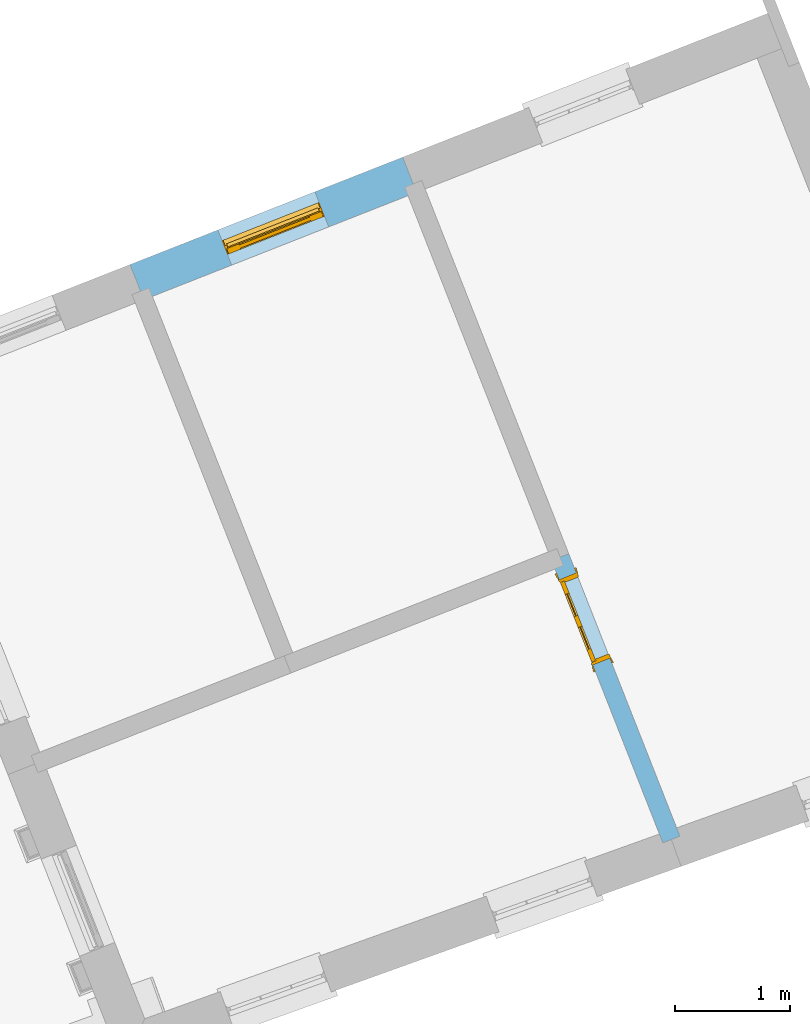
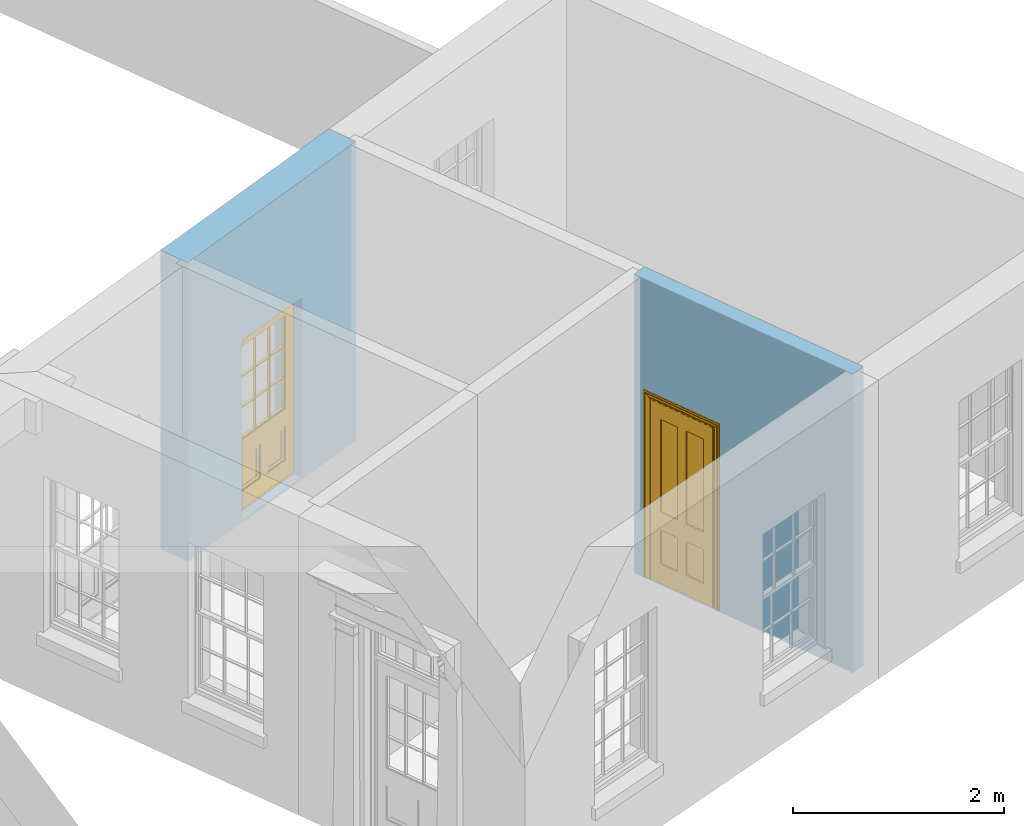
# One storey, part 6 of 8: 2 doors, 2 openings, plus 2 elements that do not belong to this part.
"""IFC2X3 building model written with IfcOpenShell, lengths in metres."""

from ifc_helpers import new_model, si_unit, frame, origin, place, context, subcontext, project, spatial, polyline, outline, extrude, faceted_brep, material, layer, layer_set, layer_usage, element, fill, save


model = new_model("IFC2X3")

# Units and contexts
model_context = context("Model", 3, world=origin())
body_context = subcontext(model_context, "Body", "Model", "MODEL_VIEW")
ifc_project = project(units=[si_unit("PLANEANGLEUNIT", "RADIAN"), si_unit("MASSUNIT", "GRAM", prefix="KILO"), si_unit("FORCEUNIT", "NEWTON", prefix="KILO"), si_unit("LENGTHUNIT", "METRE")], contexts=[model_context])

# Site, building, storey
site_placement = place(None, origin())
site = spatial("IfcSite", under=ifc_project, at=site_placement, CompositionType="ELEMENT")
building_placement = place(None, origin())
building = spatial("IfcBuilding", under=site, at=building_placement, Name="Building plot-4", CompositionType="ELEMENT")
storey_placement = place(None, frame((0.0, 0.0, 3.0)))
storey = spatial("IfcBuildingStorey", under=building, at=storey_placement, Name="Floor 0", CompositionType="ELEMENT", Elevation=3.0)

# Wall, opening, door
ifc_material_1 = material(Name="Masonry")
ifc_layer_1 = layer(ifc_material_1, 0.33, ventilated=False)
ifc_layer_set_1 = layer_set([ifc_layer_1], Name="My Wall")
ifc_layer_usage_1 = layer_usage(ifc_layer_set_1, "AXIS2", "NEGATIVE", 0.08)
wall_1_placement = place(storey_placement, origin())
wall_1 = element("IfcWallStandardCase", 1, at=wall_1_placement, inside=storey, material=ifc_layer_usage_1, Name="exterior", context=body_context, shape_type="SweptSolid", body=[
    extrude(outline(polyline([(52.0366920680449, 53.7732303747513), (51.9157706887258, 54.0802776349957), (49.5373999145512, 53.1436274453256), (49.6583212938703, 52.8365801850812), (52.0366920680449, 53.7732303747513)])), origin(), (0.0, 0.0, 1.0), 3.45),
])
opening_1_placement = place(storey_placement, frame((0.0, 0.0, 0.02)))
opening_1 = element("IfcOpeningElement", 2, at=opening_1_placement, cuts=wall_1, Name="Opening", ObjectType="Opening", context=body_context, shape_type="SweptSolid", body=[
    extrude(outline(polyline([(51.1499383422784, 53.7786774722522), (50.3032322609986, 53.4452276080691), (50.4241536403177, 53.1381803478247), (51.2708597215976, 53.4716302120078), (51.1499383422784, 53.7786774722522)])), origin(), (0.0, 0.0, 1.0), 2.08),
])
door_1_placement = place(storey_placement, frame((51.2415454478232, 53.546065911461, 0.02), z_axis=(0.0, 0.0, 1.0), x_axis=(-0.846706081279841, -0.333449864183102, 0.0)))
door_1 = element("IfcDoor", 3, at=door_1_placement, inside=storey, Name="bedroom door", OverallHeight=2.08, OverallWidth=0.91, context=body_context, shape_type="Brep", held_by="IfcProductRepresentation", body=[
    faceted_brep([(0.545, -0.055, 0.265), (0.745, -0.055, 0.265), (0.745, -0.05, 0.265), (0.545, -0.05, 0.265), (0.745, -0.05, 0.58), (0.545, -0.05, 0.58), (0.545, -0.055, 0.58), (0.515, -0.06, 0.235), (0.775, -0.06, 0.235), (0.745, -0.055, 0.58), (0.515, -0.06, 0.61), (0.515, -0.065, 0.235), (0.775, -0.065, 0.235), (0.775, -0.06, 0.61), (0.515, -0.065, 0.61), (0.785, -0.065, 0.225), (0.505, -0.065, 0.225), (0.775, -0.065, 0.61), (0.505, -0.065, 0.62), (0.785, -0.065, 0.62), (0.505, -0.07, 0.225), (0.785, -0.07, 0.225), (0.505, -0.07, 0.62), (0.785, -0.07, 0.62), (0.883, -0.07, 0.075), (0.898, -0.07, 0.075), (0.405, -0.07, 0.62), (0.405, -0.07, 0.225), (0.027, -0.07, 0.075), (0.785, -0.07, 0.82), (0.125, -0.07, 0.82), (0.405, -0.065, 0.62), (0.405, -0.065, 0.225), (0.898, -0.07, 2.068), (0.027, -0.08, 0.075), (0.883, -0.08, 0.075), (0.125, -0.07, 0.225), (0.012, -0.07, 0.075), (0.785, -0.06, 0.82), (0.125, -0.06, 0.82), (0.125, -0.07, 0.62), (0.125, -0.065, 0.62), (0.395, -0.065, 0.61), (0.395, -0.065, 0.235), (0.125, -0.065, 0.225), (0.785, -0.07, 1.895), (0.027, -0.11, 0.045), (0.883, -0.11, 0.045), (0.558333, -0.06, 0.83), (0.351667, -0.06, 0.83), (0.125, -0.07, 1.895), (0.125, -0.06, 1.895), (0.785, -0.06, 1.895), (0.012, -0.07, 2.068), (0.135, -0.065, 0.61), (0.395, -0.06, 0.61), (0.395, -0.06, 0.235), (0.135, -0.065, 0.235), (0.027, -0.11, 0.027), (0.883, -0.11, 0.027), (0.568333, -0.06, 0.83), (0.558333, -0.03, 0.83), (0.351667, -0.03, 0.83), (0.341667, -0.06, 0.83), (0.135, -0.06, 1.185), (0.135, -0.06, 1.53), (0.775, -0.06, 1.53), (0.775, -0.06, 1.185), (0.135, -0.06, 0.61), (0.365, -0.055, 0.58), (0.365, -0.055, 0.265), (0.135, -0.06, 0.235), (0.568333, -0.06, 1.175), (0.558333, -0.06, 1.175), (0.775, -0.06, 0.83), (0.558333, -0.03, 1.175), (0.785, -0.03, 0.82), (0.125, -0.03, 0.82), (0.351667, -0.03, 1.175), (0.351667, -0.06, 1.175), (0.341667, -0.06, 1.175), (0.135, -0.06, 0.83), (0.135, -0.06, 1.175), (0.135, -0.03, 1.185), (0.135, -0.03, 1.53), (0.135, -0.06, 1.54), (0.351667, -0.06, 1.885), (0.558333, -0.06, 1.885), (0.775, -0.03, 1.53), (0.775, -0.03, 1.185), (0.775, -0.06, 1.175), (0.775, -0.06, 1.54), (0.165, -0.055, 0.58), (0.365, -0.05, 0.58), (0.365, -0.05, 0.265), (0.165, -0.055, 0.265), (0.568333, -0.03, 0.83), (0.568333, -0.03, 1.175), (0.568333, -0.06, 1.185), (0.558333, -0.06, 1.185), (0.775, -0.03, 0.83), (0.785, -0.02, 0.82), (0.125, -0.02, 0.82), (0.341667, -0.03, 0.83), (0.341667, -0.03, 1.175), (0.351667, -0.06, 1.185), (0.341667, -0.06, 1.185), (0.135, -0.03, 0.83), (0.341667, -0.03, 1.185), (0.125, -0.03, 1.895), (0.341667, -0.03, 1.53), (0.341667, -0.06, 1.53), (0.135, -0.06, 1.885), (0.341667, -0.06, 1.54), (0.341667, -0.06, 1.885), (0.558333, -0.03, 1.885), (0.351667, -0.03, 1.885), (0.568333, -0.06, 1.885), (0.785, -0.03, 1.895), (0.568333, -0.03, 1.185), (0.568333, -0.06, 1.53), (0.568333, -0.03, 1.53), (0.568333, -0.06, 1.54), (0.775, -0.06, 1.885), (0.165, -0.05, 0.58), (0.165, -0.05, 0.265), (0.775, -0.03, 1.175), (0.558333, -0.06, 1.53), (0.351667, -0.03, 1.185), (0.558333, -0.03, 1.185), (0.505, -0.02, 0.62), (0.405, -0.02, 0.62), (0.125, -0.02, 1.895), (0.785, -0.02, 1.895), (0.351667, -0.06, 1.53), (0.135, -0.03, 1.175), (0.135, -0.03, 1.54), (0.341667, -0.03, 1.54), (0.135, -0.03, 1.885), (0.351667, -0.06, 1.54), (0.558333, -0.03, 1.54), (0.558333, -0.06, 1.54), (0.351667, -0.03, 1.54), (0.775, -0.03, 1.54), (0.568333, -0.03, 1.54), (0.775, -0.03, 1.885), (0.558333, -0.03, 1.53), (0.405, -0.02, 0.225), (0.505, -0.02, 0.225), (0.125, -0.02, 0.62), (0.785, -0.02, 0.62), (0.012, -0.02, 2.068), (0.898, -0.02, 2.068), (0.351667, -0.03, 1.53), (0.341667, -0.03, 1.885), (0.568333, -0.03, 1.885), (0.405, -0.025, 0.225), (0.405, -0.025, 0.62), (0.505, -0.025, 0.62), (0.505, -0.025, 0.225), (0.898, -0.02, 0.027), (0.012, -0.02, 0.027), (0.125, -0.025, 0.62), (0.785, -0.025, 0.62), (0.395, -0.025, 0.235), (0.395, -0.025, 0.61), (0.125, -0.02, 0.225), (0.125, -0.025, 0.225), (0.515, -0.025, 0.61), (0.515, -0.025, 0.235), (0.785, -0.02, 0.225), (0.785, -0.025, 0.225), (0.135, -0.025, 0.61), (0.775, -0.025, 0.61), (0.135, -0.025, 0.235), (0.395, -0.03, 0.235), (0.395, -0.03, 0.61), (0.515, -0.03, 0.61), (0.515, -0.03, 0.235), (0.775, -0.025, 0.235), (0.135, -0.03, 0.61), (0.775, -0.03, 0.61), (0.135, -0.03, 0.235), (0.365, -0.035, 0.265), (0.365, -0.035, 0.58), (0.545, -0.035, 0.58), (0.545, -0.035, 0.265), (0.775, -0.03, 0.235), (0.165, -0.035, 0.58), (0.745, -0.035, 0.58), (0.165, -0.035, 0.265), (0.365, -0.04, 0.58), (0.365, -0.04, 0.265), (0.545, -0.04, 0.58), (0.545, -0.04, 0.265), (0.745, -0.035, 0.265), (0.165, -0.04, 0.58), (0.745, -0.04, 0.58), (0.165, -0.04, 0.265), (0.745, -0.04, 0.265), (0.885, -0.072, 0.025), (0.025, -0.072, 0.025), (0.025, -0.1, 0.025), (0.885, -0.1, 0.025), (0.9, -0.02, 0.025), (0.01, -0.02, 0.025), (0.9, -0.072, 0.025), (0.91, -0.02, 0.0), (0.0, -0.02, 0.0), (0.01, -0.072, 0.025), (0.9, -0.072, 2.07), (0.9, -0.02, 2.07), (0.885, -0.072, 2.055), (0.91, -0.02, 2.08), (0.01, -0.02, 2.07), (0.0, -0.02, 2.08), (0.01, -0.072, 2.07), (0.025, -0.072, 2.055), (0.0, -0.15, 2.08), (0.91, -0.15, 2.08), (0.01, -0.15, 2.07), (0.9, -0.15, 2.07), (0.01, -0.1, 2.07), (0.9, -0.1, 2.07), (0.0, -0.15, 0.0), (0.91, -0.15, 0.0), (0.01, -0.15, 0.025), (0.9, -0.15, 0.025), (0.01, -0.1, 0.025), (0.025, -0.1, 2.055), (0.9, -0.1, 0.025), (0.885, -0.1, 2.055), (0.898, -0.07, 0.027), (0.012, -0.07, 0.027), (0.883, -0.07, 0.027), (0.027, -0.07, 0.027)], [[[0, 1, 2, 3]], [[2, 4, 5, 3]], [[0, 3, 5, 6]], [[1, 0, 7, 8]], [[9, 4, 2, 1]], [[9, 6, 5, 4]], [[0, 6, 10, 7]], [[8, 7, 11, 12]], [[8, 13, 9, 1]], [[13, 10, 6, 9]], [[7, 10, 14, 11]], [[15, 12, 11, 16]], [[12, 17, 13, 8]], [[17, 14, 10, 13]], [[18, 16, 11, 14]], [[15, 19, 17, 12]], [[15, 16, 20, 21]], [[14, 17, 19, 18]], [[16, 18, 22, 20]], [[21, 23, 19, 15]], [[24, 25, 21, 20]], [[23, 22, 18, 19]], [[20, 22, 26, 27]], [[23, 21, 25]], [[28, 24, 20, 27]], [[22, 23, 29]], [[29, 30, 26, 22]], [[27, 26, 31, 32]], [[23, 25, 33, 29]], [[34, 35, 24, 28]], [[28, 27, 36, 37]], [[38, 39, 30, 29]], [[26, 30, 40]], [[26, 40, 41, 31]], [[42, 43, 32, 31]], [[32, 44, 36, 27]], [[33, 45, 29]], [[46, 47, 35, 34]], [[36, 40, 37]], [[39, 38, 48, 49]], [[50, 30, 39, 51]], [[29, 45, 52, 38]], [[53, 37, 40, 30]], [[44, 41, 40, 36]], [[31, 41, 54, 42]], [[43, 42, 55, 56]], [[57, 44, 32, 43]], [[50, 45, 33, 53]], [[47, 46, 58, 59]], [[60, 48, 38]], [[49, 48, 61, 62]], [[49, 63, 39]], [[50, 53, 30]], [[51, 39, 64, 65]], [[45, 50, 51, 52]], [[66, 67, 38, 52]], [[57, 54, 41, 44]], [[42, 54, 68, 55]], [[56, 55, 69, 70]], [[56, 71, 57, 43]], [[60, 72, 73, 48]], [[60, 38, 74]], [[48, 73, 75, 61]], [[76, 77, 62, 61]], [[62, 78, 79, 49]], [[49, 79, 80, 63]], [[63, 81, 39]], [[82, 64, 39]], [[65, 64, 83, 84]], [[85, 51, 65]], [[52, 51, 86, 87]], [[88, 89, 67, 66]], [[90, 38, 67]], [[91, 66, 52]], [[71, 68, 54, 57]], [[55, 68, 92, 69]], [[69, 93, 94, 70]], [[70, 95, 71, 56]], [[96, 97, 72, 60]], [[73, 72, 98, 99]], [[74, 38, 90]], [[100, 96, 60, 74]], [[75, 73, 79, 78]], [[61, 75, 97, 96]], [[101, 102, 77, 76]], [[77, 103, 62]], [[96, 76, 61]], [[103, 104, 78, 62]], [[80, 79, 105, 106]], [[63, 80, 104, 103]], [[81, 63, 103, 107]], [[81, 82, 39]], [[106, 64, 82, 80]], [[106, 108, 83, 64]], [[84, 83, 77, 109]], [[110, 111, 65, 84]], [[112, 51, 85]], [[113, 85, 65, 111]], [[114, 86, 51]], [[115, 87, 86, 116]], [[117, 52, 87]], [[118, 76, 89, 88]], [[119, 98, 67, 89]], [[120, 121, 88, 66]], [[67, 98, 72, 90]], [[91, 122, 120, 66]], [[91, 52, 123]], [[95, 92, 68, 71]], [[69, 92, 124, 93]], [[94, 93, 124, 125]], [[94, 125, 95, 70]], [[72, 97, 126, 90]], [[127, 99, 98, 120]], [[99, 105, 79, 73]], [[74, 90, 126, 100]], [[96, 100, 76]], [[128, 129, 75, 78]], [[97, 75, 129, 119]], [[130, 131, 102, 101]], [[109, 77, 102, 132]], [[133, 101, 76, 118]], [[77, 107, 103]], [[78, 104, 108, 128]], [[111, 106, 105, 134]], [[104, 80, 82, 135]], [[107, 135, 82, 81]], [[110, 108, 106, 111]], [[104, 135, 83, 108]], [[83, 135, 77]], [[136, 84, 109]], [[110, 84, 136, 137]], [[114, 51, 112]], [[85, 136, 138, 112]], [[113, 137, 136, 85]], [[111, 134, 139, 113]], [[86, 114, 113, 139]], [[140, 141, 87, 115]], [[139, 142, 116, 86]], [[109, 118, 115, 116]], [[117, 123, 52]], [[117, 87, 141, 122]], [[126, 89, 76]], [[143, 118, 88]], [[120, 98, 119, 121]], [[119, 89, 126, 97]], [[144, 143, 88, 121]], [[144, 122, 91, 143]], [[127, 120, 122, 141]], [[143, 91, 123, 145]], [[124, 92, 95, 125]], [[146, 129, 99, 127]], [[99, 129, 128, 105]], [[100, 126, 76]], [[121, 119, 129, 146]], [[147, 131, 130, 148]], [[131, 149, 102]], [[130, 101, 150]], [[102, 151, 132]], [[118, 109, 132, 133]], [[101, 133, 152]], [[107, 77, 135]], [[153, 128, 108, 110]], [[134, 105, 128, 153]], [[109, 138, 136]], [[153, 110, 137, 142]], [[154, 114, 112, 138]], [[137, 113, 114, 154]], [[141, 139, 134, 127]], [[141, 140, 142, 139]], [[144, 140, 115, 155]], [[142, 137, 154, 116]], [[155, 115, 118]], [[116, 154, 109]], [[117, 155, 145, 123]], [[122, 144, 155, 117]], [[143, 145, 118]], [[121, 146, 140, 144]], [[146, 127, 134, 153]], [[156, 157, 131, 147]], [[148, 130, 158, 159]], [[148, 160, 161, 147]], [[157, 162, 149, 131]], [[161, 151, 102, 149]], [[101, 152, 160, 150]], [[163, 158, 130, 150]], [[151, 152, 133, 132]], [[154, 138, 109]], [[142, 140, 146, 153]], [[145, 155, 118]], [[157, 156, 164, 165]], [[147, 166, 167, 156]], [[168, 169, 159, 158]], [[170, 148, 159, 171]], [[148, 170, 160]], [[166, 147, 161]], [[172, 162, 157, 165]], [[166, 149, 162, 167]], [[166, 161, 149]], [[150, 160, 170]], [[163, 173, 168, 158]], [[171, 163, 150, 170]], [[174, 164, 156, 167]], [[175, 176, 165, 164]], [[169, 168, 177, 178]], [[171, 159, 169, 179]], [[167, 162, 172, 174]], [[176, 180, 172, 165]], [[179, 173, 163, 171]], [[181, 177, 168, 173]], [[164, 174, 182, 175]], [[183, 184, 176, 175]], [[178, 177, 185, 186]], [[179, 169, 178, 187]], [[174, 172, 180, 182]], [[184, 188, 180, 176]], [[187, 181, 173, 179]], [[189, 185, 177, 181]], [[175, 182, 190, 183]], [[191, 184, 183, 192]], [[185, 193, 194, 186]], [[187, 178, 186, 195]], [[182, 180, 188, 190]], [[191, 196, 188, 184]], [[195, 189, 181, 187]], [[197, 193, 185, 189]], [[183, 190, 198, 192]], [[198, 196, 191, 192]], [[194, 193, 197, 199]], [[195, 186, 194, 199]], [[188, 196, 198, 190]], [[197, 189, 195, 199]], [[200, 201, 202, 203]], [[201, 200, 204, 205]], [[206, 204, 200]], [[204, 207, 208, 205]], [[209, 201, 205]], [[210, 211, 204, 206]], [[206, 200, 212, 210]], [[211, 213, 207, 204]], [[214, 205, 208, 215]], [[216, 217, 201, 209]], [[205, 214, 216, 209]], [[216, 214, 211, 210]], [[210, 212, 217, 216]], [[214, 215, 213, 211]], [[218, 219, 213, 215]], [[219, 218, 220, 221]], [[221, 220, 222, 223]], [[215, 208, 224, 218]], [[225, 224, 208, 207]], [[224, 226, 220, 218]], [[224, 225, 227, 226]], [[219, 225, 207, 213]], [[228, 222, 220, 226]], [[219, 221, 227, 225]], [[226, 227, 203, 202]], [[202, 229, 222, 228]], [[228, 226, 202]], [[227, 221, 223, 230]], [[230, 203, 227]], [[217, 229, 202, 201]], [[231, 223, 222, 229]], [[230, 223, 231, 203]], [[231, 229, 217, 212]], [[212, 200, 203, 231]], [[33, 152, 151, 53]], [[25, 160, 152, 33]], [[161, 37, 53, 151]], [[232, 160, 25]], [[161, 233, 37]], [[160, 232, 234]], [[24, 234, 232, 25]], [[233, 161, 235]], [[37, 233, 235, 28]], [[161, 160, 234, 235]], [[35, 47, 234, 24]], [[28, 235, 46, 34]], [[58, 235, 234, 59]], [[59, 234, 47]], [[58, 46, 235]]]),
])
fill(opening_1, door_1)

ifc_material_2 = material(Name="Masonry")
ifc_layer_2 = layer(ifc_material_2, 0.16, ventilated=False)
ifc_layer_set_2 = layer_set([ifc_layer_2], Name="My Wall")
ifc_layer_usage_2 = layer_usage(ifc_layer_set_2, "AXIS2", "NEGATIVE", 0.08)
wall_2_placement = place(storey_placement, origin())
wall_2 = element("IfcWallStandardCase", 4, at=wall_2_placement, inside=storey, material=ifc_layer_usage_2, Name="interior", context=body_context, shape_type="SweptSolid", body=[
    extrude(outline(polyline([(54.1850919906856, 48.0996239867093), (54.333963389592, 48.1582525342579), (53.3639971862187, 50.6212203481571), (53.2151257873123, 50.5625918006085), (54.1850919906856, 48.0996239867093)])), origin(), (0.0, 0.0, 1.0), 3.45),
])
opening_2_placement = place(storey_placement, frame((0.0, 0.0, 0.02)))
opening_2 = element("IfcOpeningElement", 5, at=opening_2_placement, cuts=wall_2, Name="Opening", ObjectType="Opening", context=body_context, shape_type="SweptSolid", body=[
    extrude(outline(polyline([(53.7230970399543, 49.7093830298558), (53.4299543022109, 50.4537400243875), (53.2810829033046, 50.3951114768388), (53.574225641048, 49.6507544823071), (53.7230970399543, 49.7093830298558)])), origin(), (0.0, 0.0, 1.0), 2.1),
])
door_2_placement = place(storey_placement, frame((53.6486613405012, 49.6800687560814, 0.02), z_axis=(0.0, 0.0, 1.0), x_axis=(-0.293142737743402, 0.744356994531728, 0.0)))
door_2 = element("IfcDoor", 6, at=door_2_placement, inside=storey, Name="living inside door", OverallHeight=2.1, OverallWidth=0.8, context=body_context, shape_type="Brep", held_by="IfcProductRepresentation", body=[
    faceted_brep([(0.773, 0.08, 1.895), (0.66, 0.08, 1.895), (0.66, 0.08, 2.073), (0.773, 0.08, 2.073), (0.773, 0.08, 0.82), (0.66, 0.08, 0.82), (0.45, 0.08, 1.895), (0.45, 0.08, 2.073), (0.773, 0.08, 0.62), (0.66, 0.08, 0.62), (0.66, 0.065, 0.82), (0.66, 0.065, 1.895), (0.45, 0.065, 1.895), (0.35, 0.08, 1.895), (0.35, 0.08, 2.073), (0.773, 0.08, 0.225), (0.66, 0.08, 0.225), (0.45, 0.08, 0.62), (0.45, 0.08, 0.82), (0.45, 0.065, 0.82), (0.35, 0.08, 0.82), (0.14, 0.08, 2.073), (0.14, 0.08, 1.895), (0.773, 0.08, 0.0), (0.66, 0.08, 0.0), (0.66, 0.065, 0.225), (0.66, 0.065, 0.62), (0.45, 0.065, 0.62), (0.35, 0.08, 0.62), (0.35, 0.065, 0.82), (0.35, 0.065, 1.895), (0.14, 0.065, 1.895), (0.027, 0.08, 2.073), (0.027, 0.08, 1.895), (0.773, 0.042, 0.0), (0.66, 0.042, 0.0), (0.45, 0.08, 0.0), (0.45, 0.08, 0.225), (0.45, 0.065, 0.225), (0.35, 0.08, 0.225), (0.14, 0.08, 0.82), (0.14, 0.08, 0.62), (0.14, 0.065, 0.82), (0.027, 0.08, 0.82), (0.773, 0.042, 0.225), (0.66, 0.042, 0.225), (0.45, 0.042, 0.0), (0.35, 0.08, 0.0), (0.35, 0.065, 0.225), (0.35, 0.065, 0.62), (0.14, 0.065, 0.62), (0.027, 0.08, 0.62), (0.773, 0.042, 0.62), (0.66, 0.042, 0.62), (0.45, 0.042, 0.225), (0.35, 0.042, 0.0), (0.14, 0.08, 0.225), (0.14, 0.08, 0.0), (0.14, 0.065, 0.225), (0.027, 0.08, 0.225), (0.773, 0.042, 0.82), (0.66, 0.042, 0.82), (0.66, 0.057, 0.62), (0.66, 0.057, 0.225), (0.45, 0.057, 0.225), (0.35, 0.042, 0.225), (0.14, 0.042, 0.0), (0.027, 0.08, 0.0), (0.773, 0.042, 1.895), (0.66, 0.042, 1.895), (0.45, 0.042, 0.62), (0.45, 0.042, 0.82), (0.45, 0.057, 0.62), (0.35, 0.042, 0.62), (0.14, 0.042, 0.225), (0.027, 0.042, 0.0), (0.773, 0.042, 2.073), (0.66, 0.042, 2.073), (0.66, 0.057, 1.895), (0.66, 0.057, 0.82), (0.45, 0.057, 0.82), (0.35, 0.042, 0.82), (0.35, 0.057, 0.62), (0.35, 0.057, 0.225), (0.14, 0.057, 0.225), (0.027, 0.042, 0.225), (0.45, 0.042, 1.895), (0.45, 0.042, 2.073), (0.45, 0.057, 1.895), (0.35, 0.042, 1.895), (0.14, 0.042, 0.82), (0.14, 0.042, 0.62), (0.14, 0.057, 0.62), (0.027, 0.042, 0.62), (0.35, 0.042, 2.073), (0.35, 0.057, 1.895), (0.35, 0.057, 0.82), (0.14, 0.057, 0.82), (0.027, 0.042, 0.82), (0.14, 0.042, 2.073), (0.14, 0.042, 1.895), (0.14, 0.057, 1.895), (0.027, 0.042, 1.895), (0.027, 0.042, 2.073), (0.02, 0.085, 0.0), (0.005, 0.09, 0.0), (0.005, 0.09, 2.095), (0.02, 0.085, 2.08), (0.02, 0.08, 0.0), (0.0, 0.085, 0.0), (0.0, 0.085, 2.1), (0.795, 0.09, 2.095), (0.78, 0.085, 2.08), (0.02, 0.08, 2.08), (0.0, 0.08, 0.0), (-0.032, 0.095, 0.0), (-0.032, 0.095, 2.132), (0.8, 0.085, 2.1), (0.795, 0.09, 0.0), (0.78, 0.085, 0.0), (0.78, 0.08, 2.08), (0.04, 0.04, 0.0), (0.025, 0.04, 0.0), (0.025, 0.04, 2.075), (0.04, 0.04, 2.06), (-0.04, 0.09, 0.0), (-0.04, 0.09, 2.14), (0.832, 0.095, 2.132), (0.8, 0.085, 0.0), (0.78, 0.08, 0.0), (0.8, 0.08, 0.0), (0.86, 0.08, 0.0), (0.86, 0.08, 2.16), (0.8, 0.08, 2.1), (-0.06, 0.08, 2.16), (0.0, 0.08, 2.1), (-0.06, 0.08, 0.0), (-0.04, 0.095, 0.0), (-0.04, 0.095, 2.14), (0.84, 0.09, 2.14), (0.832, 0.095, 0.0), (0.84, 0.09, 0.0), (0.86, 0.095, 0.0), (0.86, 0.095, 2.16), (-0.06, 0.095, 2.16), (-0.06, 0.095, 0.0), (0.84, 0.095, 0.0), (0.84, 0.095, 2.14), (-0.025, -0.095, 0.0), (-0.025, -0.09, 0.0), (-0.025, -0.09, 2.125), (-0.025, -0.095, 2.125), (-0.017, -0.095, 0.0), (-0.017, -0.095, 2.117), (0.825, -0.09, 2.125), (0.825, -0.095, 2.125), (0.825, -0.095, 0.0), (0.845, -0.095, 0.0), (-0.045, -0.095, 2.145), (-0.045, -0.095, 0.0), (0.845, -0.095, 2.145), (0.015, -0.085, 0.0), (0.015, -0.085, 2.085), (0.817, -0.095, 2.117), (0.825, -0.09, 0.0), (0.845, -0.08, 0.0), (0.845, -0.08, 2.145), (-0.045, -0.08, 2.145), (-0.045, -0.08, 0.0), (0.02, -0.09, 0.0), (0.02, -0.09, 2.08), (0.785, -0.085, 2.085), (0.817, -0.095, 0.0), (0.8, -0.08, 0.0), (0.8, -0.08, 2.1), (0.0, -0.08, 2.1), (0.0, -0.08, 0.0), (0.035, -0.085, 0.0), (0.035, -0.085, 2.065), (0.78, -0.09, 2.08), (0.785, -0.085, 0.0), (0.775, 0.04, 2.075), (0.76, 0.04, 2.06), (0.035, -0.08, 2.065), (0.035, -0.08, 0.0), (0.765, -0.085, 2.065), (0.78, -0.09, 0.0), (0.765, -0.08, 0.0), (0.765, -0.08, 2.065), (0.765, -0.085, 0.0), (0.04, -0.08, 2.06), (0.04, -0.08, 0.0), (0.76, -0.08, 2.06), (0.76, -0.08, 0.0), (0.76, 0.04, 0.0), (0.775, 0.04, 0.0), (0.025, 0.08, 0.0), (0.025, 0.08, 2.075), (0.775, 0.08, 0.0), (0.775, 0.08, 2.075)], [[[0, 1, 2, 3]], [[1, 0, 4, 5]], [[1, 6, 7, 2]], [[8, 9, 5, 4]], [[1, 5, 10, 11]], [[6, 1, 11, 12]], [[6, 13, 14, 7]], [[15, 16, 9, 8]], [[9, 17, 18, 5]], [[5, 18, 19, 10]], [[10, 19, 12, 11]], [[18, 6, 12, 19]], [[18, 20, 13, 6]], [[21, 14, 13, 22]], [[23, 24, 16, 15]], [[9, 16, 25, 26]], [[17, 9, 26, 27]], [[17, 28, 20, 18]], [[13, 20, 29, 30]], [[22, 13, 30, 31]], [[32, 21, 22, 33]], [[34, 35, 24, 23]], [[24, 36, 37, 16]], [[16, 37, 38, 25]], [[25, 38, 27, 26]], [[37, 17, 27, 38]], [[37, 39, 28, 17]], [[40, 20, 28, 41]], [[20, 40, 42, 29]], [[31, 30, 29, 42]], [[40, 22, 31, 42]], [[33, 22, 40, 43]], [[35, 34, 44, 45]], [[35, 46, 36, 24]], [[36, 47, 39, 37]], [[28, 39, 48, 49]], [[41, 28, 49, 50]], [[43, 40, 41, 51]], [[45, 44, 52, 53]], [[46, 35, 45, 54]], [[46, 55, 47, 36]], [[56, 39, 47, 57]], [[39, 56, 58, 48]], [[50, 49, 48, 58]], [[56, 41, 50, 58]], [[51, 41, 56, 59]], [[53, 52, 60, 61]], [[45, 53, 62, 63]], [[54, 45, 63, 64]], [[55, 46, 54, 65]], [[55, 66, 57, 47]], [[59, 56, 57, 67]], [[61, 60, 68, 69]], [[70, 53, 61, 71]], [[53, 70, 72, 62]], [[72, 64, 63, 62]], [[70, 54, 64, 72]], [[65, 54, 70, 73]], [[65, 74, 66, 55]], [[67, 57, 66, 75]], [[69, 68, 76, 77]], [[61, 69, 78, 79]], [[71, 61, 79, 80]], [[73, 70, 71, 81]], [[65, 73, 82, 83]], [[74, 65, 83, 84]], [[74, 85, 75, 66]], [[86, 69, 77, 87]], [[69, 86, 88, 78]], [[88, 80, 79, 78]], [[86, 71, 80, 88]], [[81, 71, 86, 89]], [[73, 81, 90, 91]], [[73, 91, 92, 82]], [[83, 82, 92, 84]], [[91, 74, 84, 92]], [[91, 93, 85, 74]], [[89, 86, 87, 94]], [[81, 89, 95, 96]], [[90, 81, 96, 97]], [[90, 98, 93, 91]], [[94, 99, 100, 89]], [[89, 100, 101, 95]], [[101, 97, 96, 95]], [[100, 90, 97, 101]], [[100, 102, 98, 90]], [[99, 103, 102, 100]], [[32, 103, 99, 21]], [[102, 103, 32, 33]], [[98, 102, 33, 43]], [[21, 99, 94, 14]], [[94, 87, 7, 14]], [[7, 87, 77, 2]], [[76, 3, 2, 77]], [[43, 51, 93, 98]], [[51, 59, 85, 93]], [[67, 75, 85, 59]], [[34, 23, 15, 44]], [[44, 15, 8, 52]], [[52, 8, 4, 60]], [[0, 68, 60, 4]], [[0, 3, 76, 68]], [[104, 105, 106, 107]], [[104, 108, 109, 105]], [[105, 109, 110, 106]], [[107, 106, 111, 112]], [[107, 113, 108, 104]], [[114, 109, 108]], [[109, 115, 116, 110]], [[106, 110, 117, 111]], [[112, 111, 118, 119]], [[113, 107, 112, 120]], [[121, 122, 123, 124]], [[115, 109, 114, 125]], [[115, 125, 126, 116]], [[110, 116, 127, 117]], [[111, 117, 128, 118]], [[118, 128, 129, 119]], [[120, 112, 119, 129]], [[130, 129, 128]], [[130, 131, 132, 133]], [[133, 132, 134, 135]], [[135, 134, 136, 114]], [[136, 125, 114]], [[125, 137, 138, 126]], [[116, 126, 139, 127]], [[117, 127, 140, 128]], [[141, 130, 128, 140]], [[131, 130, 141]], [[131, 142, 143, 132]], [[132, 143, 144, 134]], [[134, 144, 145, 136]], [[137, 125, 136, 145]], [[143, 142, 146]], [[143, 146, 147]], [[137, 145, 144]], [[143, 147, 138]], [[138, 137, 144]], [[143, 138, 144]], [[126, 138, 147, 139]], [[127, 139, 141, 140]], [[142, 131, 141, 146]], [[139, 147, 146, 141]], [[148, 149, 150, 151]], [[149, 152, 153, 150]], [[151, 150, 154, 155]], [[155, 156, 157]], [[158, 159, 148]], [[158, 148, 151]], [[155, 157, 160]], [[158, 151, 155]], [[155, 160, 158]], [[152, 161, 162, 153]], [[150, 153, 163, 154]], [[155, 154, 164, 156]], [[156, 164, 165, 157]], [[157, 165, 166, 160]], [[160, 166, 167, 158]], [[158, 167, 168, 159]], [[161, 169, 170, 162]], [[153, 162, 171, 163]], [[154, 163, 172, 164]], [[165, 164, 173]], [[165, 173, 174, 166]], [[166, 174, 175, 167]], [[167, 175, 176, 168]], [[169, 177, 178, 170]], [[162, 170, 179, 171]], [[163, 171, 180, 172]], [[172, 180, 173, 164]], [[124, 123, 181, 182]], [[183, 178, 177, 184]], [[170, 178, 185, 179]], [[171, 179, 186, 180]], [[187, 173, 180]], [[185, 188, 187, 189]], [[188, 185, 178, 183]], [[179, 185, 189, 186]], [[189, 187, 180, 186]], [[190, 183, 184, 191]], [[192, 188, 183, 190]], [[191, 184, 122, 121]], [[124, 190, 191, 121]], [[193, 187, 188, 192]], [[182, 192, 190, 124]], [[184, 176, 122]], [[194, 195, 187, 193]], [[192, 182, 194, 193]], [[161, 176, 184]], [[114, 108, 122, 176]], [[173, 187, 195]], [[152, 149, 176, 161]], [[169, 161, 184, 177]], [[196, 122, 108]], [[176, 175, 135, 114]], [[173, 195, 129, 130]], [[176, 149, 168]], [[123, 122, 196, 197]], [[196, 108, 113, 197]], [[175, 174, 133, 135]], [[198, 129, 195]], [[133, 174, 173, 130]], [[159, 168, 149, 148]], [[181, 123, 197, 199]], [[197, 113, 120, 199]], [[199, 120, 129, 198]], [[195, 181, 199, 198]], [[195, 194, 182, 181]]]),
])
fill(opening_2, door_2)

save(model, "model.ifc")
